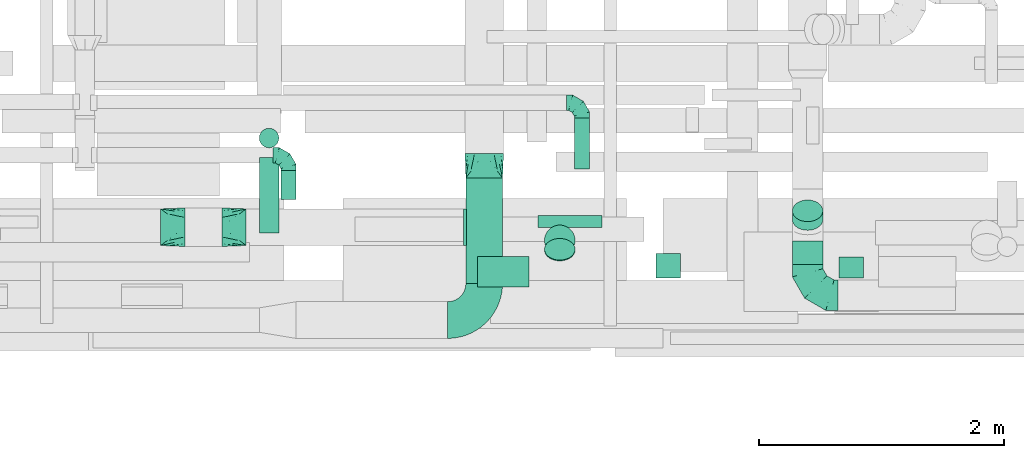
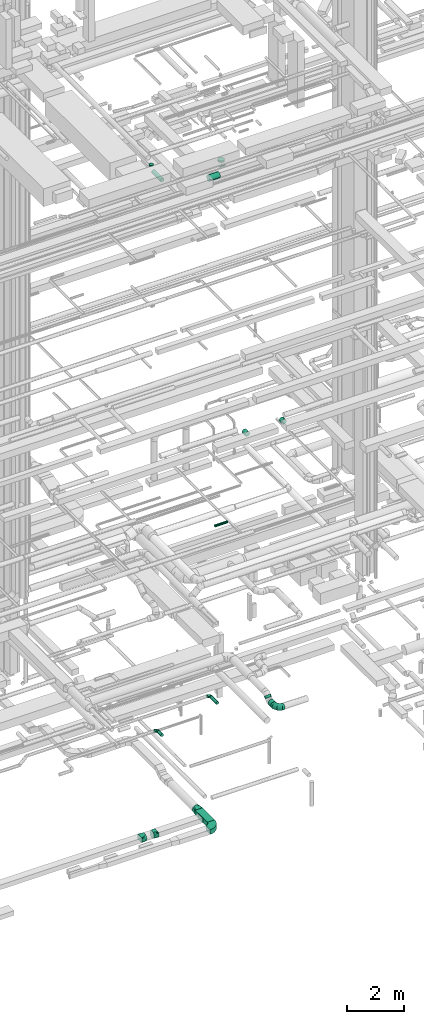
# One storey, part 122 of 337: 13 flow segments, 8 flow fittings.
"""IFC2X3 building model written with IfcOpenShell, lengths in millimetres."""

from ifc_helpers import new_model, entity, si_unit, converted_unit, derived_unit, direction, frame, frame_2d, origin, origin_2d_with_axis, place, context, subcontext, project, spatial, polyline, circle_curve, parameter, trimmed, segment, composite_curve, rectangle, circle, outline, extrude, faceted_brep, source, transform, mapped, material, type_object, type_shapes, element, save


model = new_model("IFC2X3")

# Units and contexts
model_context = context("Model", 3, precision=0.01, world=origin(), true_north=direction((6.12303176911189e-17, 1.0)))
body_context = subcontext(model_context, "Body", "Model", "MODEL_VIEW")
ifc_project = project(units=[si_unit("LENGTHUNIT", "METRE", prefix="MILLI"), si_unit("AREAUNIT", "SQUARE_METRE"), si_unit("VOLUMEUNIT", "CUBIC_METRE"), converted_unit("PLANEANGLEUNIT", "DEGREE", entity("IfcRatioMeasure", 0.0174532925199433), si_unit("PLANEANGLEUNIT", "RADIAN"), dimensions=[0, 0, 0, 0, 0, 0, 0]), si_unit("MASSUNIT", "GRAM", prefix="KILO"), derived_unit("MASSDENSITYUNIT", [(si_unit("MASSUNIT", "GRAM", prefix="KILO"), 1), (si_unit("LENGTHUNIT", "METRE"), -3)]), derived_unit("MOMENTOFINERTIAUNIT", [(si_unit("LENGTHUNIT", "METRE"), 4)]), si_unit("TIMEUNIT", "SECOND"), si_unit("FREQUENCYUNIT", "HERTZ"), si_unit("THERMODYNAMICTEMPERATUREUNIT", "DEGREE_CELSIUS"), derived_unit("THERMALTRANSMITTANCEUNIT", [(si_unit("MASSUNIT", "GRAM", prefix="KILO"), 1), (si_unit("THERMODYNAMICTEMPERATUREUNIT", "KELVIN"), -1), (si_unit("TIMEUNIT", "SECOND"), -3)]), derived_unit("VOLUMETRICFLOWRATEUNIT", [(si_unit("LENGTHUNIT", "METRE"), 3), (si_unit("TIMEUNIT", "SECOND"), -1)]), derived_unit("MASSFLOWRATEUNIT", [(si_unit("MASSUNIT", "GRAM", prefix="KILO"), 1), (si_unit("TIMEUNIT", "SECOND"), -1)]), derived_unit("ROTATIONALFREQUENCYUNIT", [(si_unit("TIMEUNIT", "SECOND"), -1)]), si_unit("ELECTRICCURRENTUNIT", "AMPERE"), si_unit("ELECTRICVOLTAGEUNIT", "VOLT"), si_unit("POWERUNIT", "WATT"), si_unit("FORCEUNIT", "NEWTON", prefix="KILO"), si_unit("ILLUMINANCEUNIT", "LUX"), si_unit("LUMINOUSFLUXUNIT", "LUMEN"), si_unit("LUMINOUSINTENSITYUNIT", "CANDELA"), derived_unit("USERDEFINED", [(si_unit("MASSUNIT", "GRAM", prefix="KILO"), -1), (si_unit("LENGTHUNIT", "METRE"), -2), (si_unit("TIMEUNIT", "SECOND"), 3), (si_unit("LUMINOUSFLUXUNIT", "LUMEN"), 1)]), derived_unit("LINEARVELOCITYUNIT", [(si_unit("LENGTHUNIT", "METRE"), 1), (si_unit("TIMEUNIT", "SECOND"), -1)]), si_unit("PRESSUREUNIT", "PASCAL"), derived_unit("USERDEFINED", [(si_unit("LENGTHUNIT", "METRE"), -2), (si_unit("MASSUNIT", "GRAM", prefix="KILO"), 1), (si_unit("TIMEUNIT", "SECOND"), -2)]), derived_unit("LINEARFORCEUNIT", [(si_unit("MASSUNIT", "GRAM", prefix="KILO"), 1), (si_unit("LENGTHUNIT", "METRE"), 1), (si_unit("TIMEUNIT", "SECOND"), -2), (si_unit("LENGTHUNIT", "METRE"), -1)]), derived_unit("PLANARFORCEUNIT", [(si_unit("MASSUNIT", "GRAM", prefix="KILO"), 1), (si_unit("LENGTHUNIT", "METRE"), 1), (si_unit("TIMEUNIT", "SECOND"), -2), (si_unit("LENGTHUNIT", "METRE"), -2)])], contexts=[model_context])

# Site, building, storey
site_placement = place(None, origin())
site = spatial("IfcSite", under=ifc_project, at=site_placement, CompositionType="ELEMENT")
building_placement = place(site_placement, origin())
building = spatial("IfcBuilding", under=site, at=building_placement, CompositionType="ELEMENT")
storey_placement = place(building_placement, origin())
storey = spatial("IfcBuildingStorey", under=building, at=storey_placement, CompositionType="ELEMENT", Elevation=0.0)

# Flow segments
duct_segment_type_1 = type_object("IfcDuctSegmentType", PredefinedType="NOTDEFINED")
flow_segment_1_placement = place(storey_placement, frame((32739.74, 948.22, -1000.0)))
element("IfcFlowSegment", 1, at=flow_segment_1_placement, inside=storey, type_object=duct_segment_type_1, context=body_context, shape_type="SweptSolid", body=[
    extrude(rectangle(XDim=861.350764015482, YDim=300.000000000001, at=origin_2d_with_axis()), frame((150.0, 430.68, 0.0), z_axis=(0.0, 0.0, 1.0), x_axis=(0.0, -1.0, 0.0)), (0.0, 0.0, 1.0), 200.0),
])
duct_segment_type_2 = type_object("IfcDuctSegmentType", PredefinedType="NOTDEFINED")
flow_segment_2_placement = place(storey_placement, frame((33330.5, 1401.97, 11418.4)))
element("IfcFlowSegment", 2, at=flow_segment_2_placement, inside=storey, type_object=duct_segment_type_2, context=body_context, shape_type="SweptSolid", body=[
    extrude(circle(Radius=50.0, at=origin_2d_with_axis()), frame((0.0, 51.6, 51.6), z_axis=(1.0, 0.0, 0.0), x_axis=(0.0, 1.0, 0.0)), (0.0, 0.0, 1.0), 520.000000000155),
])
flow_segment_3_placement = place(storey_placement, frame((33624.11, 1884.63, 3385.9)))
element("IfcFlowSegment", 3, at=flow_segment_3_placement, inside=storey, type_object=duct_segment_type_2, context=body_context, shape_type="SweptSolid", body=[
    extrude(circle(Radius=62.5, at=origin_2d_with_axis()), frame((64.1, 0.0, 64.1), z_axis=(0.0, 1.0, 0.0), x_axis=(-1.0, 0.0, 0.0)), (0.0, 0.0, 1.0), 415.000000000007),
])
flow_segment_4_placement = place(storey_placement, frame((35406.66, 1101.79, 3073.4)))
element("IfcFlowSegment", 4, at=flow_segment_4_placement, inside=storey, type_object=duct_segment_type_2, context=body_context, shape_type="SweptSolid", body=[
    extrude(circle(Radius=125.0, at=origin_2d_with_axis()), frame((126.6, 0.0, 126.6), z_axis=(0.0, 1.0, 0.0), x_axis=(1.0, 0.0, 0.0)), (0.0, 0.0, 1.0), 192.16662774988),
])
flow_segment_5_placement = place(storey_placement, frame((35406.66, 1380.75, 3183.24)))
element("IfcFlowSegment", 5, at=flow_segment_5_placement, inside=storey, type_object=duct_segment_type_2, context=body_context, shape_type="SweptSolid", body=[
    extrude(circle(Radius=125.0, at=origin_2d_with_axis()), frame((126.6, 89.98, 89.98), z_axis=(0.0, 0.707106792500235, 0.70710676987286), x_axis=(1.0, 0.0, 0.0)), (0.0, 0.0, 1.0), 100.484678237325),
])
flow_segment_6_placement = place(storey_placement, frame((31224.93, 1635.7, 2985.9)))
element("IfcFlowSegment", 6, at=flow_segment_6_placement, inside=storey, type_object=duct_segment_type_2, context=body_context, shape_type="SweptSolid", body=[
    extrude(circle(Radius=62.5, at=origin_2d_with_axis()), frame((64.1, 0.0, 64.1), z_axis=(0.0, 1.0, 0.0), x_axis=(-1.0, 0.0, 0.0)), (0.0, 0.0, 1.0), 235.000000000007),
])
flow_segment_7_placement = place(storey_placement, frame((34293.48, 990.66, 15248.4)))
element("IfcFlowSegment", 7, at=flow_segment_7_placement, inside=storey, type_object=duct_segment_type_2, context=body_context, shape_type="SweptSolid", body=[
    extrude(circle(Radius=100.0, at=origin_2d_with_axis()), frame((101.6, 0.0, 101.6), z_axis=(0.0, 1.0, 0.0), x_axis=(1.0, 0.0, 0.0)), (0.0, 0.0, 1.0), 200.000000000613),
])
flow_segment_8_placement = place(storey_placement, frame((35788.15, 990.66, 15248.4)))
element("IfcFlowSegment", 8, at=flow_segment_8_placement, inside=storey, type_object=duct_segment_type_2, context=body_context, shape_type="SweptSolid", body=[
    extrude(circle(Radius=100.0, at=origin_2d_with_axis()), frame((101.6, 0.0, 101.6), z_axis=(0.0, 1.0, 0.0), x_axis=(1.0, 0.0, 0.0)), (0.0, 0.0, 1.0), 171.742634045112),
])
flow_segment_9_placement = place(storey_placement, frame((31048.91, 1361.51, 27138.4)))
element("IfcFlowSegment", 9, at=flow_segment_9_placement, inside=storey, type_object=duct_segment_type_2, context=body_context, shape_type="SweptSolid", body=[
    extrude(circle(Radius=80.0, at=origin_2d_with_axis()), frame((81.6, 0.0, 81.6), z_axis=(0.0, 1.0, 0.0), x_axis=(1.0, 0.0, 0.0)), (0.0, 0.0, 1.0), 615.000000000009),
])
flow_segment_10_placement = place(storey_placement, frame((31048.91, 2054.91, 27380.0)))
element("IfcFlowSegment", 10, at=flow_segment_10_placement, inside=storey, type_object=duct_segment_type_2, context=body_context, shape_type="SweptSolid", body=[
    extrude(circle(Radius=80.0, at=origin_2d_with_axis()), frame((81.6, 81.6, 0.0)), (0.0, 0.0, 1.0), 60.0000000000167),
])
flow_segment_11_placement = place(storey_placement, frame((32834.8, 916.58, 26773.4)))
element("IfcFlowSegment", 11, at=flow_segment_11_placement, inside=storey, type_object=duct_segment_type_2, context=body_context, shape_type="SweptSolid", body=[
    extrude(circle(Radius=125.0, at=origin_2d_with_axis()), frame((0.0, 126.6, 126.6), z_axis=(1.0, 0.0, 0.0), x_axis=(0.0, 1.0, 0.0)), (0.0, 0.0, 1.0), 422.500000000012),
])
flow_segment_12_placement = place(storey_placement, frame((33380.71, 1129.97, 26986.79)))
element("IfcFlowSegment", 12, at=flow_segment_12_placement, inside=storey, type_object=duct_segment_type_2, context=body_context, shape_type="SweptSolid", body=[
    extrude(circle(Radius=125.0, at=origin_2d_with_axis()), frame((126.6, 89.98, 89.98), z_axis=(0.0, 0.707106781186545, 0.70710678118655), x_axis=(1.0, 0.0, 0.0)), (0.0, 0.0, 1.0), 9.87806691190423),
])
flow_segment_13_placement = place(storey_placement, frame((33380.71, 1173.56, 27260.54)))
element("IfcFlowSegment", 13, at=flow_segment_13_placement, inside=storey, type_object=duct_segment_type_2, context=body_context, shape_type="SweptSolid", body=[
    extrude(circle(Radius=125.0, at=origin_2d_with_axis()), frame((126.6, 126.6, 0.0), z_axis=(0.0, 0.0, 1.0), x_axis=(0.0, 1.0, 0.0)), (0.0, 0.0, 1.0), 69.4617613085419),
])

# Flow fittings
ifc_material = material()
duct_fitting_type_1 = type_object("IfcDuctFittingType", PredefinedType="NOTDEFINED", material=ifc_material)
shared_shape_1 = source(origin(), body_context, "Body", "SweptSolid", [
    extrude(rectangle(XDim=26.096000000001, YDim=300.0, at=origin_2d_with_axis()), frame((6.95, 0.0, -100.0)), (0.0, 0.0, 1.0), 200.0),
])
type_shapes(duct_fitting_type_1, [shared_shape_1])
flow_fitting_1_placement = place(storey_placement, frame((32739.74, 1407.6, -900.0), z_axis=(0.0, 0.0, -1.0), x_axis=(-1.0, 0.0, 0.0)))
element("IfcFlowFitting", 14, at=flow_fitting_1_placement, inside=storey, type_object=duct_fitting_type_1, material=ifc_material, context=body_context, shape_type="MappedRepresentation", body=[
    mapped(shared_shape_1, transform((0.0, 0.0, 0.0), scale=1.0)),
])
duct_fitting_type_2 = type_object("IfcDuctFittingType", PredefinedType="NOTDEFINED", material=ifc_material)
shared_shape_2 = source(origin(), body_context, "Body", "Brep", [
    faceted_brep([(-250.0, 0.0, -125.0), (-250.0, -32.35, -120.74), (-250.0, -62.5, -108.25), (-250.0, -88.39, -88.39), (-250.0, -108.25, -62.5), (-250.0, -120.74, -32.35), (-250.0, -125.0, 0.0), (-250.0, -120.74, 32.35), (-250.0, -108.25, 62.5), (-250.0, -88.39, 88.39), (-250.0, -62.5, 108.25), (-250.0, -32.35, 120.74), (-250.0, 0.0, 125.0), (-250.0, 32.35, 120.74), (-250.0, 62.5, 108.25), (-250.0, 88.39, 88.39), (-250.0, 108.25, 62.5), (-250.0, 120.74, 32.35), (-250.0, 125.0, 0.0), (-250.0, 120.74, -32.35), (-250.0, 108.25, -62.5), (-250.0, 88.39, -88.39), (-250.0, 62.5, -108.25), (-250.0, 32.35, -120.74), (-191.68, 32.35, 120.74), (-199.76, 62.5, 108.25), (-183.01, 0.0, 125.0), (-206.7, 88.39, 88.39), (-215.37, 120.74, 32.35), (-216.51, 125.0, 0.0), (-212.02, 108.25, 62.5), (-212.02, 108.25, -62.5), (-206.7, 88.39, -88.39), (-215.37, 120.74, -32.35), (-191.68, 32.35, -120.74), (-183.01, 0.0, -125.0), (-199.76, 62.5, -108.25), (-174.34, -32.35, -120.74), (-166.27, -62.5, -108.25), (-159.33, -88.39, -88.39), (-154.01, -108.25, -62.5), (-150.66, -120.74, -32.35), (-149.52, -125.0, 0.0), (-150.66, -120.74, 32.35), (-154.01, -108.25, 62.5), (-159.33, -88.39, 88.39), (-166.27, -62.5, 108.25), (-174.34, -32.35, 120.74), (-90.67, 90.67, 120.74), (-112.74, 112.74, 108.25), (-66.99, 66.99, 125.0), (-131.69, 131.69, 88.39), (-146.23, 146.23, 62.5), (-155.38, 155.38, 32.35), (-158.49, 158.49, 0.0), (-155.38, 155.38, -32.35), (-146.23, 146.23, -62.5), (-131.69, 131.69, -88.39), (-90.67, 90.67, -120.74), (-66.99, 66.99, -125.0), (-112.74, 112.74, -108.25), (-43.3, 43.3, -120.74), (-21.23, 21.23, -108.25), (-2.28, 2.28, -88.39), (12.26, -12.26, -62.5), (21.4, -21.4, -32.35), (24.52, -24.52, 0.0), (21.4, -21.4, 32.35), (12.26, -12.26, 62.5), (-2.28, 2.28, 88.39), (-21.23, 21.23, 108.25), (-43.3, 43.3, 120.74), (-32.35, 191.68, 120.74), (-62.5, 199.76, 108.25), (0.0, 183.01, 125.0), (-88.39, 206.7, 88.39), (-108.25, 212.02, 62.5), (-120.74, 215.37, 32.35), (-125.0, 216.51, 0.0), (-120.74, 215.37, -32.35), (-108.25, 212.02, -62.5), (-88.39, 206.7, -88.39), (-32.35, 191.68, -120.74), (0.0, 183.01, -125.0), (-62.5, 199.76, -108.25), (32.35, 174.34, -120.74), (62.5, 166.27, -108.25), (88.39, 159.33, -88.39), (108.25, 154.01, -62.5), (120.74, 150.66, -32.35), (125.0, 149.52, 0.0), (120.74, 150.66, 32.35), (108.25, 154.01, 62.5), (88.39, 159.33, 88.39), (62.5, 166.27, 108.25), (32.35, 174.34, 120.74), (-32.35, 250.0, -120.74), (-62.5, 250.0, -108.25), (-88.39, 250.0, -88.39), (-108.25, 250.0, -62.5), (-120.74, 250.0, -32.35), (-125.0, 250.0, 0.0), (-120.74, 250.0, 32.35), (-108.25, 250.0, 62.5), (-88.39, 250.0, 88.39), (-62.5, 250.0, 108.25), (-32.35, 250.0, 120.74), (0.0, 250.0, 125.0), (32.35, 250.0, 120.74), (62.5, 250.0, 108.25), (88.39, 250.0, 88.39), (108.25, 250.0, 62.5), (120.74, 250.0, 32.35), (125.0, 250.0, 0.0), (120.74, 250.0, -32.35), (108.25, 250.0, -62.5), (88.39, 250.0, -88.39), (62.5, 250.0, -108.25), (32.35, 250.0, -120.74), (0.0, 250.0, -125.0)], [[[0, 1, 2, 3, 4, 5, 6, 7, 8, 9, 10, 11, 12, 13, 14, 15, 16, 17, 18, 19, 20, 21, 22, 23]], [[24, 25, 14, 13]], [[26, 24, 13, 12]], [[14, 25, 27, 15]], [[28, 29, 18, 17]], [[30, 28, 17, 16]], [[15, 27, 30, 16]], [[20, 31, 32, 21]], [[33, 31, 20, 19]], [[18, 29, 33, 19]], [[34, 35, 0, 23]], [[36, 34, 23, 22]], [[21, 32, 36, 22]], [[1, 0, 35, 37]], [[2, 1, 37, 38]], [[38, 39, 3, 2]], [[5, 4, 40, 41]], [[6, 5, 41, 42]], [[39, 40, 4, 3]], [[6, 42, 43, 7]], [[7, 43, 44, 8]], [[8, 44, 45, 9]], [[9, 45, 46, 10]], [[10, 46, 47, 11]], [[26, 12, 11, 47]], [[48, 49, 25, 24]], [[50, 48, 24, 26]], [[27, 25, 49, 51]], [[52, 53, 28, 30]], [[51, 52, 30, 27]], [[29, 28, 53, 54]], [[55, 56, 31, 33]], [[54, 55, 33, 29]], [[32, 31, 56, 57]], [[58, 59, 35, 34]], [[60, 58, 34, 36]], [[57, 60, 36, 32]], [[37, 35, 59, 61]], [[38, 37, 61, 62]], [[39, 38, 62, 63]], [[41, 40, 64, 65]], [[42, 41, 65, 66]], [[63, 64, 40, 39]], [[43, 42, 66, 67]], [[44, 43, 67, 68]], [[68, 69, 45, 44]], [[46, 45, 69, 70]], [[47, 46, 70, 71]], [[26, 47, 71, 50]], [[72, 73, 49, 48]], [[74, 72, 48, 50]], [[51, 49, 73, 75]], [[76, 77, 53, 52]], [[75, 76, 52, 51]], [[54, 53, 77, 78]], [[79, 80, 56, 55]], [[78, 79, 55, 54]], [[57, 56, 80, 81]], [[82, 83, 59, 58]], [[84, 82, 58, 60]], [[81, 84, 60, 57]], [[61, 59, 83, 85]], [[62, 61, 85, 86]], [[63, 62, 86, 87]], [[65, 64, 88, 89]], [[66, 65, 89, 90]], [[87, 88, 64, 63]], [[67, 66, 90, 91]], [[68, 67, 91, 92]], [[92, 93, 69, 68]], [[70, 69, 93, 94]], [[71, 70, 94, 95]], [[50, 71, 95, 74]], [[96, 97, 98, 99, 100, 101, 102, 103, 104, 105, 106, 107, 108, 109, 110, 111, 112, 113, 114, 115, 116, 117, 118, 119]], [[72, 74, 107, 106]], [[73, 72, 106, 105]], [[75, 73, 105, 104]], [[77, 76, 103, 102]], [[78, 77, 102, 101]], [[75, 104, 103, 76]], [[78, 101, 100, 79]], [[79, 100, 99, 80]], [[80, 99, 98, 81]], [[84, 97, 96, 82]], [[82, 96, 119, 83]], [[84, 81, 98, 97]], [[83, 119, 118, 85]], [[85, 118, 117, 86]], [[116, 87, 86, 117]], [[88, 115, 114, 89]], [[89, 114, 113, 90]], [[115, 88, 87, 116]], [[91, 90, 113, 112]], [[92, 91, 112, 111]], [[111, 110, 93, 92]], [[95, 94, 109, 108]], [[74, 95, 108, 107]], [[110, 109, 94, 93]]]),
])
type_shapes(duct_fitting_type_2, [shared_shape_2])
flow_fitting_2_placement = place(storey_placement, frame((35533.26, 851.79, 3200.0), z_axis=(0.0, 0.0, 1.0), x_axis=(0.0, -1.0, 0.0)))
element("IfcFlowFitting", 15, at=flow_fitting_2_placement, inside=storey, type_object=duct_fitting_type_2, material=ifc_material, context=body_context, shape_type="MappedRepresentation", body=[
    mapped(shared_shape_2, transform((0.0, 0.0, 0.0), scale=1.0)),
])
duct_fitting_type_3 = type_object("IfcDuctFittingType", PredefinedType="NOTDEFINED", material=ifc_material)
shared_shape_3 = source(origin(), body_context, "Body", "Brep", [
    faceted_brep([(-125.0, 0.0, -62.5), (-125.0, -16.18, -60.37), (-125.0, -31.25, -54.13), (-125.0, -44.19, -44.19), (-125.0, -54.13, -31.25), (-125.0, -60.37, -16.18), (-125.0, -62.5, 0.0), (-125.0, -60.37, 16.18), (-125.0, -54.13, 31.25), (-125.0, -44.19, 44.19), (-125.0, -31.25, 54.13), (-125.0, -16.18, 60.37), (-125.0, 0.0, 62.5), (-125.0, 16.18, 60.37), (-125.0, 31.25, 54.13), (-125.0, 44.19, 44.19), (-125.0, 54.13, 31.25), (-125.0, 60.37, 16.18), (-125.0, 62.5, 0.0), (-125.0, 60.37, -16.18), (-125.0, 54.13, -31.25), (-125.0, 44.19, -44.19), (-125.0, 31.25, -54.13), (-125.0, 16.18, -60.37), (-95.84, 16.18, 60.37), (-99.88, 31.25, 54.13), (-91.51, 0.0, 62.5), (-103.35, 44.19, 44.19), (-107.68, 60.37, 16.18), (-108.25, 62.5, 0.0), (-106.01, 54.13, 31.25), (-106.01, 54.13, -31.25), (-103.35, 44.19, -44.19), (-107.68, 60.37, -16.18), (-95.84, 16.18, -60.37), (-91.51, 0.0, -62.5), (-99.88, 31.25, -54.13), (-87.17, -16.18, -60.37), (-83.13, -31.25, -54.13), (-79.66, -44.19, -44.19), (-77.0, -54.13, -31.25), (-75.33, -60.37, -16.18), (-74.76, -62.5, 0.0), (-75.33, -60.37, 16.18), (-77.0, -54.13, 31.25), (-79.66, -44.19, 44.19), (-83.13, -31.25, 54.13), (-87.17, -16.18, 60.37), (-45.34, 45.34, 60.37), (-56.37, 56.37, 54.13), (-33.49, 33.49, 62.5), (-65.85, 65.85, 44.19), (-73.12, 73.12, 31.25), (-77.69, 77.69, 16.18), (-79.25, 79.25, 0.0), (-77.69, 77.69, -16.18), (-73.12, 73.12, -31.25), (-65.85, 65.85, -44.19), (-45.34, 45.34, -60.37), (-33.49, 33.49, -62.5), (-56.37, 56.37, -54.13), (-21.65, 21.65, -60.37), (-10.62, 10.62, -54.13), (-1.14, 1.14, -44.19), (6.13, -6.13, -31.25), (10.7, -10.7, -16.18), (12.26, -12.26, 0.0), (10.7, -10.7, 16.18), (6.13, -6.13, 31.25), (-1.14, 1.14, 44.19), (-10.62, 10.62, 54.13), (-21.65, 21.65, 60.37), (-16.18, 95.84, 60.37), (-31.25, 99.88, 54.13), (0.0, 91.51, 62.5), (-44.19, 103.35, 44.19), (-54.13, 106.01, 31.25), (-60.37, 107.68, 16.18), (-62.5, 108.25, 0.0), (-60.37, 107.68, -16.18), (-54.13, 106.01, -31.25), (-44.19, 103.35, -44.19), (-16.18, 95.84, -60.37), (0.0, 91.51, -62.5), (-31.25, 99.88, -54.13), (16.18, 87.17, -60.37), (31.25, 83.13, -54.13), (44.19, 79.66, -44.19), (54.13, 77.0, -31.25), (60.37, 75.33, -16.18), (62.5, 74.76, 0.0), (60.37, 75.33, 16.18), (54.13, 77.0, 31.25), (44.19, 79.66, 44.19), (31.25, 83.13, 54.13), (16.18, 87.17, 60.37), (-16.18, 125.0, -60.37), (-31.25, 125.0, -54.13), (-44.19, 125.0, -44.19), (-54.13, 125.0, -31.25), (-60.37, 125.0, -16.18), (-62.5, 125.0, 0.0), (-60.37, 125.0, 16.18), (-54.13, 125.0, 31.25), (-44.19, 125.0, 44.19), (-31.25, 125.0, 54.13), (-16.18, 125.0, 60.37), (0.0, 125.0, 62.5), (16.18, 125.0, 60.37), (31.25, 125.0, 54.13), (44.19, 125.0, 44.19), (54.13, 125.0, 31.25), (60.37, 125.0, 16.18), (62.5, 125.0, 0.0), (60.37, 125.0, -16.18), (54.13, 125.0, -31.25), (44.19, 125.0, -44.19), (31.25, 125.0, -54.13), (16.18, 125.0, -60.37), (0.0, 125.0, -62.5)], [[[0, 1, 2, 3, 4, 5, 6, 7, 8, 9, 10, 11, 12, 13, 14, 15, 16, 17, 18, 19, 20, 21, 22, 23]], [[24, 25, 14, 13]], [[26, 24, 13, 12]], [[14, 25, 27, 15]], [[28, 29, 18, 17]], [[30, 28, 17, 16]], [[15, 27, 30, 16]], [[20, 31, 32, 21]], [[33, 31, 20, 19]], [[18, 29, 33, 19]], [[34, 35, 0, 23]], [[36, 34, 23, 22]], [[21, 32, 36, 22]], [[1, 0, 35, 37]], [[2, 1, 37, 38]], [[38, 39, 3, 2]], [[5, 4, 40, 41]], [[6, 5, 41, 42]], [[39, 40, 4, 3]], [[6, 42, 43, 7]], [[7, 43, 44, 8]], [[45, 9, 8, 44]], [[9, 45, 46, 10]], [[10, 46, 47, 11]], [[26, 12, 11, 47]], [[48, 49, 25, 24]], [[50, 48, 24, 26]], [[27, 25, 49, 51]], [[52, 53, 28, 30]], [[51, 52, 30, 27]], [[29, 28, 53, 54]], [[55, 56, 31, 33]], [[54, 55, 33, 29]], [[57, 32, 31, 56]], [[58, 59, 35, 34]], [[60, 58, 34, 36]], [[57, 60, 36, 32]], [[37, 35, 59, 61]], [[38, 37, 61, 62]], [[39, 38, 62, 63]], [[41, 40, 64, 65]], [[42, 41, 65, 66]], [[63, 64, 40, 39]], [[43, 42, 66, 67]], [[44, 43, 67, 68]], [[68, 69, 45, 44]], [[46, 45, 69, 70]], [[47, 46, 70, 71]], [[26, 47, 71, 50]], [[72, 73, 49, 48]], [[74, 72, 48, 50]], [[51, 49, 73, 75]], [[76, 77, 53, 52]], [[75, 76, 52, 51]], [[54, 53, 77, 78]], [[79, 80, 56, 55]], [[78, 79, 55, 54]], [[81, 57, 56, 80]], [[82, 83, 59, 58]], [[84, 82, 58, 60]], [[81, 84, 60, 57]], [[61, 59, 83, 85]], [[62, 61, 85, 86]], [[63, 62, 86, 87]], [[65, 64, 88, 89]], [[66, 65, 89, 90]], [[87, 88, 64, 63]], [[67, 66, 90, 91]], [[68, 67, 91, 92]], [[92, 93, 69, 68]], [[70, 69, 93, 94]], [[71, 70, 94, 95]], [[50, 71, 95, 74]], [[96, 97, 98, 99, 100, 101, 102, 103, 104, 105, 106, 107, 108, 109, 110, 111, 112, 113, 114, 115, 116, 117, 118, 119]], [[72, 74, 107, 106]], [[73, 72, 106, 105]], [[75, 73, 105, 104]], [[77, 76, 103, 102]], [[78, 77, 102, 101]], [[75, 104, 103, 76]], [[78, 101, 100, 79]], [[79, 100, 99, 80]], [[80, 99, 98, 81]], [[96, 119, 83, 82]], [[97, 96, 82, 84]], [[84, 81, 98, 97]], [[83, 119, 118, 85]], [[85, 118, 117, 86]], [[116, 87, 86, 117]], [[88, 115, 114, 89]], [[89, 114, 113, 90]], [[115, 88, 87, 116]], [[91, 90, 113, 112]], [[92, 91, 112, 111]], [[111, 110, 93, 92]], [[95, 94, 109, 108]], [[74, 95, 108, 107]], [[110, 109, 94, 93]]]),
])
type_shapes(duct_fitting_type_3, [shared_shape_3])
for number, where, z_axis, x_axis in (
    (16, (33688.21, 2424.63, 3450.0), (0.0, 0.0, 1.0), (0.0, 1.0, 0.0)),
    (17, (31289.02, 1995.7, 3050.0), (0.0, 0.0, 1.0), (0.0, 1.0, 0.0)),
):
    element("IfcFlowFitting", number, at=place(storey_placement, frame(where, z_axis=z_axis, x_axis=x_axis)), inside=storey, type_object=duct_fitting_type_3, material=ifc_material, context=body_context, shape_type="MappedRepresentation", body=[
        mapped(shared_shape_3, transform((0.0, 0.0, 0.0), scale=1.0)),
    ])
duct_fitting_type_4 = type_object("IfcDuctFittingType", PredefinedType="NOTDEFINED", material=ifc_material)
shared_shape_4 = source(origin(), body_context, "Body", "Brep", [
    faceted_brep([(200.0, 78.75, 136.4), (200.0, 59.76, 144.27), (200.0, 40.76, 152.13), (200.0, 27.93, 153.82), (200.0, 15.1, 155.51), (200.0, 0.0, 157.5), (200.0, -15.1, 155.51), (200.0, -27.93, 153.82), (200.0, -40.76, 152.13), (200.0, -59.76, 144.27), (200.0, -78.75, 136.4), (200.0, -95.06, 123.88), (200.0, -111.37, 111.37), (200.0, -123.88, 95.06), (200.0, -136.4, 78.75), (200.0, -144.27, 59.76), (200.0, -152.13, 40.76), (200.0, -153.82, 27.93), (200.0, -155.51, 15.1), (200.0, -157.5, 0.0), (200.0, -155.51, -15.1), (200.0, -153.82, -27.93), (200.0, -152.13, -40.76), (200.0, -144.27, -59.76), (200.0, -136.4, -78.75), (200.0, -123.88, -95.06), (200.0, -111.37, -111.37), (200.0, -95.06, -123.88), (200.0, -78.75, -136.4), (200.0, -59.76, -144.27), (200.0, -40.76, -152.13), (200.0, -27.93, -153.82), (200.0, -15.1, -155.51), (200.0, 0.0, -157.5), (200.0, 15.1, -155.51), (200.0, 27.93, -153.82), (200.0, 40.76, -152.13), (200.0, 59.76, -144.27), (200.0, 78.75, -136.4), (200.0, 95.06, -123.88), (200.0, 111.37, -111.37), (200.0, 123.88, -95.06), (200.0, 136.4, -78.75), (200.0, 144.27, -59.76), (200.0, 152.13, -40.76), (200.0, 153.82, -27.93), (200.0, 155.51, -15.1), (200.0, 157.5, 0.0), (200.0, 155.51, 15.1), (200.0, 153.82, 27.93), (200.0, 152.13, 40.76), (200.0, 144.27, 59.76), (200.0, 136.4, 78.75), (200.0, 123.88, 95.06), (200.0, 111.37, 111.37), (200.0, 95.06, 123.88), (0.0, -150.0, 100.0), (0.0, 150.0, 100.0), (0.0, 150.0, -100.0), (0.0, -150.0, -100.0), (128.09, -53.94, 136.82), (104.11, -71.91, 129.93), (78.09, -91.44, 122.45), (100.0, -127.21, 108.95), (26.03, -130.48, 107.48), (52.06, -151.95, 73.97), (26.03, -150.98, 86.99), (78.09, -152.93, 60.96), (104.11, -153.9, 47.94), (128.09, -154.8, 35.96), (176.03, -17.98, 150.61), (152.06, -35.96, 143.72), (152.06, -155.7, 23.97), (176.03, -156.6, 11.99), (52.06, -110.96, 114.97), (26.03, -150.98, -86.99), (52.06, -151.95, -73.97), (78.09, -152.93, -60.96), (104.11, -153.9, -47.94), (128.09, -154.8, -35.96), (152.06, -155.7, -23.97), (176.03, -156.6, -11.99), (100.0, -133.95, -102.21), (52.06, -110.96, -114.97), (26.03, -130.48, -107.48), (78.09, -91.44, -122.45), (104.11, -71.91, -129.93), (128.09, -53.94, -136.82), (152.06, -35.96, -143.72), (176.03, -17.98, -150.61), (26.03, 130.48, -107.48), (52.06, 110.96, -114.97), (78.09, 91.44, -122.45), (104.11, 71.91, -129.93), (128.09, 53.94, -136.82), (152.06, 35.96, -143.72), (176.03, 17.98, -150.61), (100.0, 127.21, -108.95), (52.06, 151.95, -73.97), (26.03, 150.98, -86.99), (78.09, 152.93, -60.96), (104.11, 153.9, -47.94), (128.09, 154.8, -35.96), (152.06, 155.7, -23.97), (176.03, 156.6, -11.99), (26.03, 150.98, 86.99), (52.06, 151.95, 73.97), (78.09, 152.93, 60.96), (104.11, 153.9, 47.94), (128.09, 154.8, 35.96), (152.06, 155.7, 23.97), (176.03, 156.6, 11.99), (100.0, 133.95, 102.21), (52.06, 110.96, 114.97), (26.03, 130.48, 107.48), (78.09, 91.44, 122.45), (104.11, 71.91, 129.93), (128.09, 53.94, 136.82), (152.06, 35.96, 143.72), (176.03, 17.98, 150.61)], [[[0, 1, 2, 3, 4, 5, 6, 7, 8, 9, 10, 11, 12, 13, 14, 15, 16, 17, 18, 19, 20, 21, 22, 23, 24, 25, 26, 27, 28, 29, 30, 31, 32, 33, 34, 35, 36, 37, 38, 39, 40, 41, 42, 43, 44, 45, 46, 47, 48, 49, 50, 51, 52, 53, 54, 55]], [[56, 57, 58, 59]], [[60, 61, 62, 9]], [[63, 11, 64]], [[13, 12, 63]], [[8, 60, 9]], [[9, 62, 10]], [[65, 14, 13]], [[13, 63, 66]], [[15, 67, 68, 69]], [[70, 71, 60, 8, 7, 6, 5]], [[17, 16, 69, 72, 73, 19, 18]], [[15, 14, 67]], [[15, 69, 16]], [[14, 65, 67]], [[11, 74, 64]], [[11, 10, 74]], [[56, 63, 64]], [[11, 63, 12]], [[13, 66, 65]], [[63, 56, 66]], [[62, 74, 10]], [[73, 72, 69, 68, 67, 65, 66, 56, 59, 75, 76, 77, 78, 79, 80, 81, 19]], [[79, 78, 77, 23]], [[82, 25, 75]], [[27, 26, 82]], [[22, 79, 23]], [[23, 77, 24]], [[83, 28, 27]], [[27, 82, 84]], [[29, 85, 86, 87]], [[81, 80, 79, 22, 21, 20, 19]], [[31, 30, 87, 88, 89, 33, 32]], [[29, 28, 85]], [[29, 87, 30]], [[28, 83, 85]], [[25, 76, 75]], [[25, 24, 76]], [[59, 82, 75]], [[25, 82, 26]], [[27, 84, 83]], [[82, 59, 84]], [[77, 76, 24]], [[89, 88, 87, 86, 85, 83, 84, 59, 58, 90, 91, 92, 93, 94, 95, 96, 33]], [[94, 93, 92, 37]], [[97, 39, 90]], [[41, 40, 97]], [[36, 94, 37]], [[37, 92, 38]], [[98, 42, 41]], [[41, 97, 99]], [[43, 100, 101, 102]], [[96, 95, 94, 36, 35, 34, 33]], [[45, 44, 102, 103, 104, 47, 46]], [[43, 42, 100]], [[43, 102, 44]], [[42, 98, 100]], [[39, 91, 90]], [[39, 38, 91]], [[58, 97, 90]], [[39, 97, 40]], [[41, 99, 98]], [[97, 58, 99]], [[92, 91, 38]], [[58, 57, 105, 106, 107, 108, 109, 110, 111, 47, 104, 103, 102, 101, 100, 98, 99]], [[109, 108, 107, 51]], [[112, 53, 105]], [[55, 54, 112]], [[50, 109, 51]], [[51, 107, 52]], [[113, 0, 55]], [[55, 112, 114]], [[1, 115, 116, 117]], [[111, 110, 109, 50, 49, 48, 47]], [[3, 2, 117, 118, 119, 5, 4]], [[1, 0, 115]], [[1, 117, 2]], [[0, 113, 115]], [[53, 106, 105]], [[53, 52, 106]], [[57, 112, 105]], [[53, 112, 54]], [[55, 114, 113]], [[112, 57, 114]], [[107, 106, 52]], [[57, 56, 64, 74, 62, 61, 60, 71, 70, 5, 119, 118, 117, 116, 115, 113, 114]]]),
])
type_shapes(duct_fitting_type_4, [shared_shape_4])
for number, where, z_axis, x_axis in (
    (18, (32889.74, 1809.57, -900.0), (0.0, 0.0, 1.0), (0.0, 1.0, 0.0)),
    (19, (30943.84, 1407.6, -900.0), (0.0, 0.0, 1.0), (-1.0, 0.0, 0.0)),
):
    element("IfcFlowFitting", number, at=place(storey_placement, frame(where, z_axis=z_axis, x_axis=x_axis)), inside=storey, type_object=duct_fitting_type_4, material=ifc_material, context=body_context, shape_type="MappedRepresentation", body=[
        mapped(shared_shape_4, transform((0.0, 0.0, 0.0), scale=1.0)),
    ])
flow_fitting_3_placement = place(storey_placement, frame((30243.59, 1407.6, -900.0)))
element("IfcFlowFitting", 20, at=flow_fitting_3_placement, inside=storey, type_object=duct_fitting_type_4, material=ifc_material, context=body_context, shape_type="MappedRepresentation", body=[
    mapped(shared_shape_4, transform((0.0, 0.0, 0.0), scale=1.0)),
])
duct_fitting_type_5 = type_object("IfcDuctFittingType", PredefinedType="NOTDEFINED", material=ifc_material)
shared_shape_5 = source(origin(), body_context, "Body", "SweptSolid", [
    extrude(outline(composite_curve([segment(polyline([(-300.0, -150.0), (0.0, -150.0)]), True, "CONTINUOUS"), segment(trimmed(circle_curve(frame_2d((150.0, -150.0), x_axis=(0.0, 1.0)), 150.0), [parameter(0.0)], [parameter(90.0)], True, "PARAMETER"), False, "CONTINUOUS"), segment(polyline([(150.0, 0.0), (150.0, 300.0)]), True, "CONTINUOUS"), segment(trimmed(circle_curve(frame_2d((150.0, -150.0), x_axis=(0.0, 1.0)), 450.0), [parameter(0.0)], [parameter(90.0000000000001)], True, "PARAMETER"), True, "CONTINUOUS")], self_intersect=False)), frame((-150.0, 150.0, -100.0), z_axis=(0.0, 0.0, 1.0), x_axis=(-1.0, 0.0, 0.0)), (0.0, 0.0, 1.0), 200.0),
])
type_shapes(duct_fitting_type_5, [shared_shape_5])
flow_fitting_4_placement = place(storey_placement, frame((32889.74, 648.22, -900.0)))
element("IfcFlowFitting", 21, at=flow_fitting_4_placement, inside=storey, type_object=duct_fitting_type_5, material=ifc_material, context=body_context, shape_type="MappedRepresentation", body=[
    mapped(shared_shape_5, transform((0.0, 0.0, 0.0), scale=1.0)),
])

save(model, "model.ifc")
